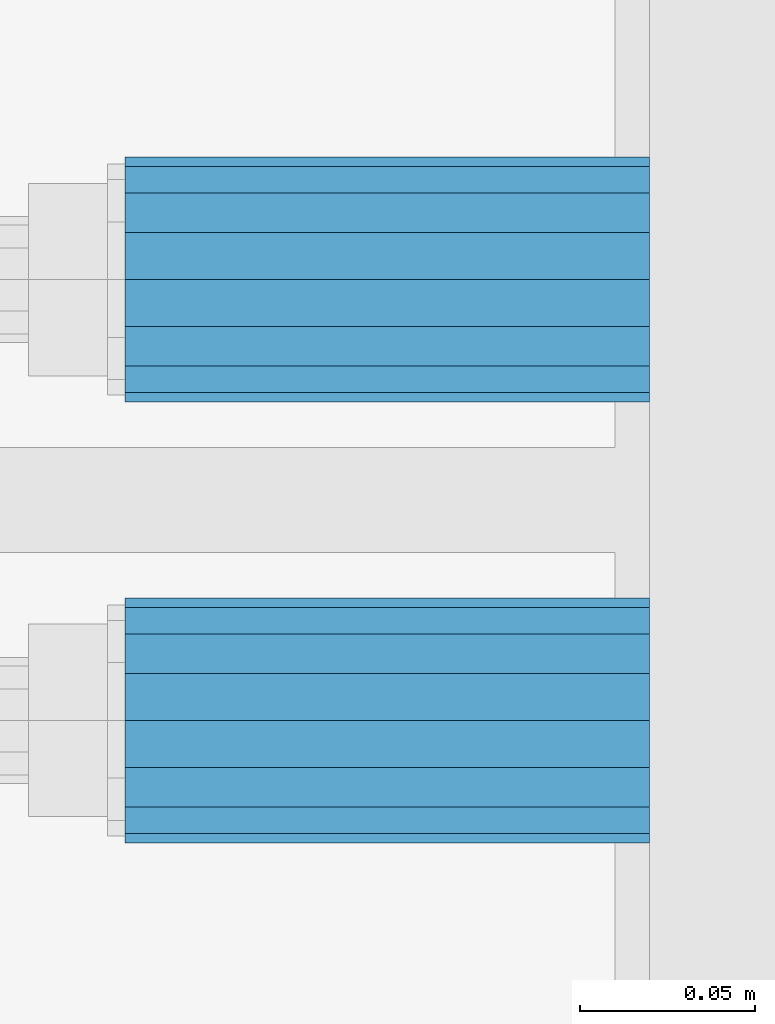
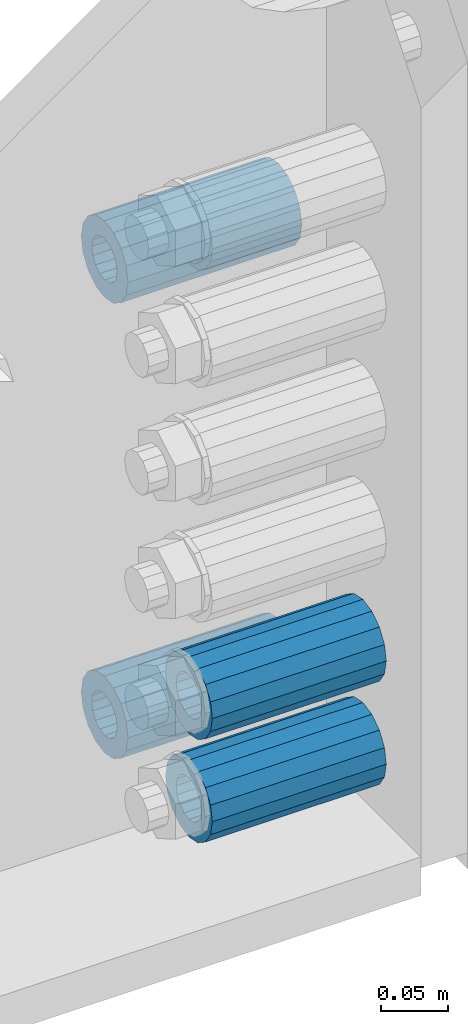
# One storey, part 177 of 270: 4 beams.
"""IFC2X3 building model written with IfcOpenShell, lengths in millimetres."""

from ifc_helpers import new_model, si_unit, frame, origin_with_axes, place, context, subcontext, project, spatial, faceted_brep, material, type_object, element, save


model = new_model("IFC2X3")

# Units and contexts
model_context = context("Model", 3, precision=1e-05, world=origin_with_axes())
body_context = subcontext(model_context, "Body", "Model", "MODEL_VIEW")
ifc_project = project(units=[si_unit("LENGTHUNIT", "METRE", prefix="MILLI"), si_unit("AREAUNIT", "SQUARE_METRE"), si_unit("VOLUMEUNIT", "CUBIC_METRE"), si_unit("MASSUNIT", "GRAM", prefix="KILO"), si_unit("TIMEUNIT", "SECOND"), si_unit("PLANEANGLEUNIT", "RADIAN"), si_unit("SOLIDANGLEUNIT", "STERADIAN"), si_unit("THERMODYNAMICTEMPERATUREUNIT", "DEGREE_CELSIUS"), si_unit("LUMINOUSINTENSITYUNIT", "LUMEN")], contexts=[model_context])

# Site, building, storey
site_placement = place(None, origin_with_axes())
site = spatial("IfcSite", under=ifc_project, at=site_placement, CompositionType="ELEMENT")
building_placement = place(site_placement, origin_with_axes())
building = spatial("IfcBuilding", under=site, at=building_placement, Name="Standard", CompositionType="ELEMENT")
storey_placement = place(building_placement, origin_with_axes())
storey = spatial("IfcBuildingStorey", under=building, at=storey_placement, Name="Undefined", CompositionType="ELEMENT", Elevation=0.0)

# Beams
ifc_material = material()
beam_type = type_object("IfcBeamType", PredefinedType="NOTDEFINED")
beam_1_placement = place(storey_placement, frame((20240.0, -17937.0, -397.0), z_axis=(0.0, 0.0, 1.0), x_axis=(1.0, 0.0, 0.0)))
element("IfcBeam", 1, at=beam_1_placement, inside=storey, type_object=beam_type, material=ifc_material, context=body_context, shape_type="Brep", body=[
    faceted_brep([(1.3317730918061e-07, -19.0000000004501, -6.27005647402257e-09), (0.0, -17.5537111177146, 7.27098521493673), (150.0, -17.5537111177146, 7.27098521493673), (150.0, -19.0, 0.0), (0.0, -13.4350288425449, 13.4350288425444), (150.0, -13.4350288425449, 13.4350288425444), (0.0, -7.27098521493826, 17.5537111177144), (150.0, -7.27098521493826, 17.5537111177144), (-6.33008312433958e-09, -4.50143033958739e-10, 18.9999999937299), (150.0, 0.0, 19.0), (0.0, 7.27098521493826, 17.5537111177144), (150.0, 7.27098521493826, 17.5537111177144), (0.0, 13.4350288425449, 13.4350288425444), (150.0, 13.4350288425449, 13.4350288425444), (0.0, 17.5537111177146, 7.27098521493673), (150.0, 17.5537111177146, 7.27098521493673), (-1.31170963868499e-07, 18.9999999995497, -6.27005647402257e-09), (150.0, 19.0, 0.0), (0.0, 17.5537111177146, -7.27098521493673), (150.0, 17.5537111177146, -7.27098521493673), (0.0, 13.4350288425449, -13.4350288425444), (150.0, 13.4350288425449, -13.4350288425444), (0.0, 7.27098521493826, -17.5537111177144), (150.0, 7.27098521493826, -17.5537111177144), (8.33460944704711e-09, -4.5025672079646e-10, -19.0000000062701), (150.0, 0.0, -19.0), (0.0, -7.27098521493826, -17.5537111177144), (150.0, -7.27098521493826, -17.5537111177144), (0.0, -13.4350288425449, -13.4350288425444), (150.0, -13.4350288425449, -13.4350288425444), (0.0, -17.5537111177146, -7.27098521493673), (150.0, -17.5537111177146, -7.27098521493673), (0.0, -35.0, -1.81898940354586e-12), (0.0, -32.335783637895, -13.3939201327794), (150.0, -32.3357836378964, -13.3939201327782), (150.0, -35.0, 0.0), (-1.81898940354586e-12, -24.7487373415292, -24.7487373415315), (150.0, -24.7487373415279, -24.7487373415292), (0.0, -13.3939201327782, -32.3357836378964), (150.0, -13.3939201327776, -32.335783637895), (0.0, 0.0, -35.0000000000018), (150.0, 0.0, -35.0), (0.0, 13.3939201327782, -32.3357836378964), (150.0, 13.3939201327776, -32.335783637895), (-1.81898940354586e-12, 24.7487373415292, -24.7487373415315), (150.0, 24.7487373415279, -24.7487373415291), (0.0, 32.335783637895, -13.3939201327794), (150.0, 32.3357836378964, -13.3939201327781), (0.0, 35.0, -1.81898940354586e-12), (150.0, 35.0, 0.0), (0.0, 32.335783637895, 13.3939201327776), (150.0, 32.3357836378964, 13.3939201327781), (1.81898940354586e-12, 24.7487373415292, 24.7487373415279), (150.0, 24.7487373415279, 24.7487373415292), (0.0, 13.3939201327781, 32.3357836378946), (150.0, 13.3939201327776, 32.335783637895), (0.0, 0.0, 34.9999999999982), (150.0, 0.0, 35.0), (0.0, -13.3939201327781, 32.3357836378946), (150.0, -13.3939201327776, 32.335783637895), (1.81898940354586e-12, -24.7487373415292, 24.7487373415279), (150.0, -24.7487373415279, 24.7487373415292), (0.0, -32.335783637895, 13.3939201327776), (150.0, -32.3357836378964, 13.3939201327781)], [[[0, 1, 2, 3]], [[1, 4, 5, 2]], [[4, 6, 7, 5]], [[6, 8, 9, 7]], [[8, 10, 11, 9]], [[10, 12, 13, 11]], [[12, 14, 15, 13]], [[14, 16, 17, 15]], [[16, 18, 19, 17]], [[18, 20, 21, 19]], [[20, 22, 23, 21]], [[22, 24, 25, 23]], [[24, 26, 27, 25]], [[26, 28, 29, 27]], [[28, 30, 31, 29]], [[30, 0, 3, 31]], [[32, 33, 34, 35]], [[33, 36, 37, 34]], [[36, 38, 39, 37]], [[38, 40, 41, 39]], [[40, 42, 43, 41]], [[42, 44, 45, 43]], [[44, 46, 47, 45]], [[46, 48, 49, 47]], [[48, 50, 51, 49]], [[50, 52, 53, 51]], [[52, 54, 55, 53]], [[54, 56, 57, 55]], [[56, 58, 59, 57]], [[58, 60, 61, 59]], [[60, 62, 63, 61]], [[62, 32, 35, 63]], [[37, 39, 41, 43, 45, 47, 49, 51, 53, 55, 57, 59, 61, 63, 35, 34], [5, 7, 9, 11, 13, 15, 17, 19, 21, 23, 25, 27, 29, 31, 3, 2]], [[62, 60, 58, 56, 54, 52, 50, 48, 46, 44, 42, 40, 38, 36, 33, 32], [30, 28, 26, 24, 22, 20, 18, 16, 14, 12, 10, 8, 6, 4, 1, 0]]]),
])
beam_2_placement = place(storey_placement, frame((20240.0, -18063.0, -718.0), z_axis=(0.0, 0.0, 1.0), x_axis=(1.0, 0.0, 0.0)))
element("IfcBeam", 2, at=beam_2_placement, inside=storey, type_object=beam_type, material=ifc_material, context=body_context, shape_type="Brep", body=[
    faceted_brep([(1.3317730918061e-07, -19.0000000004501, -6.27005647402257e-09), (0.0, -17.5537111177146, 7.27098521493673), (150.0, -17.5537111177146, 7.27098521493673), (150.0, -19.0, 0.0), (0.0, -13.4350288425449, 13.4350288425444), (150.0, -13.4350288425449, 13.4350288425444), (0.0, -7.27098521493826, 17.5537111177144), (150.0, -7.27098521493826, 17.5537111177144), (-6.33008312433958e-09, -4.50143033958739e-10, 18.9999999937299), (150.0, 0.0, 19.0), (0.0, 7.27098521493826, 17.5537111177144), (150.0, 7.27098521493826, 17.5537111177144), (0.0, 13.4350288425449, 13.4350288425444), (150.0, 13.4350288425449, 13.4350288425444), (0.0, 17.5537111177146, 7.27098521493673), (150.0, 17.5537111177146, 7.27098521493673), (-1.31170963868499e-07, 18.9999999995497, -6.27005647402257e-09), (150.0, 19.0, 0.0), (0.0, 17.5537111177146, -7.27098521493673), (150.0, 17.5537111177146, -7.27098521493673), (0.0, 13.4350288425449, -13.4350288425444), (150.0, 13.4350288425449, -13.4350288425444), (0.0, 7.27098521493826, -17.5537111177144), (150.0, 7.27098521493826, -17.5537111177144), (8.33460944704711e-09, -4.5025672079646e-10, -19.0000000062701), (150.0, 0.0, -19.0), (0.0, -7.27098521493826, -17.5537111177144), (150.0, -7.27098521493826, -17.5537111177144), (0.0, -13.4350288425449, -13.4350288425444), (150.0, -13.4350288425449, -13.4350288425444), (0.0, -17.5537111177146, -7.27098521493673), (150.0, -17.5537111177146, -7.27098521493673), (0.0, -35.0, -1.81898940354586e-12), (0.0, -32.335783637895, -13.3939201327794), (150.0, -32.3357836378964, -13.3939201327782), (150.0, -35.0, 0.0), (-1.81898940354586e-12, -24.7487373415292, -24.7487373415315), (150.0, -24.7487373415279, -24.7487373415292), (0.0, -13.3939201327782, -32.3357836378964), (150.0, -13.3939201327776, -32.335783637895), (0.0, 0.0, -35.0000000000018), (150.0, 0.0, -35.0), (0.0, 13.3939201327782, -32.3357836378964), (150.0, 13.3939201327776, -32.335783637895), (-1.81898940354586e-12, 24.7487373415292, -24.7487373415315), (150.0, 24.7487373415279, -24.7487373415291), (0.0, 32.335783637895, -13.3939201327794), (150.0, 32.3357836378964, -13.3939201327781), (0.0, 35.0, -1.81898940354586e-12), (150.0, 35.0, 0.0), (0.0, 32.335783637895, 13.3939201327776), (150.0, 32.3357836378964, 13.3939201327781), (1.81898940354586e-12, 24.7487373415292, 24.7487373415279), (150.0, 24.7487373415279, 24.7487373415292), (0.0, 13.3939201327781, 32.3357836378946), (150.0, 13.3939201327776, 32.335783637895), (0.0, 0.0, 34.9999999999982), (150.0, 0.0, 35.0), (0.0, -13.3939201327781, 32.3357836378946), (150.0, -13.3939201327776, 32.335783637895), (1.81898940354586e-12, -24.7487373415292, 24.7487373415279), (150.0, -24.7487373415279, 24.7487373415292), (0.0, -32.335783637895, 13.3939201327776), (150.0, -32.3357836378964, 13.3939201327781)], [[[0, 1, 2, 3]], [[1, 4, 5, 2]], [[4, 6, 7, 5]], [[6, 8, 9, 7]], [[8, 10, 11, 9]], [[10, 12, 13, 11]], [[12, 14, 15, 13]], [[14, 16, 17, 15]], [[16, 18, 19, 17]], [[18, 20, 21, 19]], [[20, 22, 23, 21]], [[22, 24, 25, 23]], [[24, 26, 27, 25]], [[26, 28, 29, 27]], [[28, 30, 31, 29]], [[30, 0, 3, 31]], [[32, 33, 34, 35]], [[33, 36, 37, 34]], [[36, 38, 39, 37]], [[38, 40, 41, 39]], [[40, 42, 43, 41]], [[42, 44, 45, 43]], [[44, 46, 47, 45]], [[46, 48, 49, 47]], [[48, 50, 51, 49]], [[50, 52, 53, 51]], [[52, 54, 55, 53]], [[54, 56, 57, 55]], [[56, 58, 59, 57]], [[58, 60, 61, 59]], [[60, 62, 63, 61]], [[62, 32, 35, 63]], [[37, 39, 41, 43, 45, 47, 49, 51, 53, 55, 57, 59, 61, 63, 35, 34], [5, 7, 9, 11, 13, 15, 17, 19, 21, 23, 25, 27, 29, 31, 3, 2]], [[62, 60, 58, 56, 54, 52, 50, 48, 46, 44, 42, 40, 38, 36, 33, 32], [30, 28, 26, 24, 22, 20, 18, 16, 14, 12, 10, 8, 6, 4, 1, 0]]]),
])
beam_3_placement = place(storey_placement, frame((20240.0, -17937.0, -812.0), z_axis=(0.0, 0.0, 1.0), x_axis=(1.0, 0.0, 0.0)))
element("IfcBeam", 3, at=beam_3_placement, inside=storey, type_object=beam_type, material=ifc_material, context=body_context, shape_type="Brep", body=[
    faceted_brep([(1.3317730918061e-07, -19.0000000004501, -6.27005647402257e-09), (0.0, -17.5537111177146, 7.27098521493673), (150.0, -17.5537111177146, 7.27098521493673), (150.0, -19.0, 0.0), (0.0, -13.4350288425449, 13.4350288425444), (150.0, -13.4350288425449, 13.4350288425444), (0.0, -7.27098521493826, 17.5537111177144), (150.0, -7.27098521493826, 17.5537111177144), (-6.33008312433958e-09, -4.50143033958739e-10, 18.9999999937299), (150.0, 0.0, 19.0), (0.0, 7.27098521493826, 17.5537111177144), (150.0, 7.27098521493826, 17.5537111177144), (0.0, 13.4350288425449, 13.4350288425444), (150.0, 13.4350288425449, 13.4350288425444), (0.0, 17.5537111177146, 7.27098521493673), (150.0, 17.5537111177146, 7.27098521493673), (-1.31170963868499e-07, 18.9999999995497, -6.27005647402257e-09), (150.0, 19.0, 0.0), (0.0, 17.5537111177146, -7.27098521493673), (150.0, 17.5537111177146, -7.27098521493673), (0.0, 13.4350288425449, -13.4350288425444), (150.0, 13.4350288425449, -13.4350288425444), (0.0, 7.27098521493826, -17.5537111177144), (150.0, 7.27098521493826, -17.5537111177144), (8.33460944704711e-09, -4.5025672079646e-10, -19.0000000062701), (150.0, 0.0, -19.0), (0.0, -7.27098521493826, -17.5537111177144), (150.0, -7.27098521493826, -17.5537111177144), (0.0, -13.4350288425449, -13.4350288425444), (150.0, -13.4350288425449, -13.4350288425444), (0.0, -17.5537111177146, -7.27098521493673), (150.0, -17.5537111177146, -7.27098521493673), (0.0, -35.0, -1.81898940354586e-12), (0.0, -32.335783637895, -13.3939201327794), (150.0, -32.3357836378964, -13.3939201327782), (150.0, -35.0, 0.0), (-1.81898940354586e-12, -24.7487373415292, -24.7487373415315), (150.0, -24.7487373415279, -24.7487373415292), (0.0, -13.3939201327782, -32.3357836378964), (150.0, -13.3939201327776, -32.335783637895), (0.0, 0.0, -35.0000000000018), (150.0, 0.0, -35.0), (0.0, 13.3939201327782, -32.3357836378964), (150.0, 13.3939201327776, -32.335783637895), (-1.81898940354586e-12, 24.7487373415292, -24.7487373415315), (150.0, 24.7487373415279, -24.7487373415291), (0.0, 32.335783637895, -13.3939201327794), (150.0, 32.3357836378964, -13.3939201327781), (0.0, 35.0, -1.81898940354586e-12), (150.0, 35.0, 0.0), (0.0, 32.335783637895, 13.3939201327776), (150.0, 32.3357836378964, 13.3939201327781), (1.81898940354586e-12, 24.7487373415292, 24.7487373415279), (150.0, 24.7487373415279, 24.7487373415292), (0.0, 13.3939201327781, 32.3357836378946), (150.0, 13.3939201327776, 32.335783637895), (0.0, 0.0, 34.9999999999982), (150.0, 0.0, 35.0), (0.0, -13.3939201327781, 32.3357836378946), (150.0, -13.3939201327776, 32.335783637895), (1.81898940354586e-12, -24.7487373415292, 24.7487373415279), (150.0, -24.7487373415279, 24.7487373415292), (0.0, -32.335783637895, 13.3939201327776), (150.0, -32.3357836378964, 13.3939201327781)], [[[0, 1, 2, 3]], [[1, 4, 5, 2]], [[4, 6, 7, 5]], [[6, 8, 9, 7]], [[8, 10, 11, 9]], [[10, 12, 13, 11]], [[12, 14, 15, 13]], [[14, 16, 17, 15]], [[16, 18, 19, 17]], [[18, 20, 21, 19]], [[20, 22, 23, 21]], [[22, 24, 25, 23]], [[24, 26, 27, 25]], [[26, 28, 29, 27]], [[28, 30, 31, 29]], [[30, 0, 3, 31]], [[32, 33, 34, 35]], [[33, 36, 37, 34]], [[36, 38, 39, 37]], [[38, 40, 41, 39]], [[40, 42, 43, 41]], [[42, 44, 45, 43]], [[44, 46, 47, 45]], [[46, 48, 49, 47]], [[48, 50, 51, 49]], [[50, 52, 53, 51]], [[52, 54, 55, 53]], [[54, 56, 57, 55]], [[56, 58, 59, 57]], [[58, 60, 61, 59]], [[60, 62, 63, 61]], [[62, 32, 35, 63]], [[37, 39, 41, 43, 45, 47, 49, 51, 53, 55, 57, 59, 61, 63, 35, 34], [5, 7, 9, 11, 13, 15, 17, 19, 21, 23, 25, 27, 29, 31, 3, 2]], [[62, 60, 58, 56, 54, 52, 50, 48, 46, 44, 42, 40, 38, 36, 33, 32], [30, 28, 26, 24, 22, 20, 18, 16, 14, 12, 10, 8, 6, 4, 1, 0]]]),
])
beam_4_placement = place(storey_placement, frame((20240.0, -18063.0, -812.0), z_axis=(0.0, 0.0, 1.0), x_axis=(1.0, 0.0, 0.0)))
element("IfcBeam", 4, at=beam_4_placement, inside=storey, type_object=beam_type, material=ifc_material, context=body_context, shape_type="Brep", body=[
    faceted_brep([(1.3317730918061e-07, -19.0000000004501, -6.27005647402257e-09), (0.0, -17.5537111177146, 7.27098521493673), (150.0, -17.5537111177146, 7.27098521493673), (150.0, -19.0, 0.0), (0.0, -13.4350288425449, 13.4350288425444), (150.0, -13.4350288425449, 13.4350288425444), (0.0, -7.27098521493826, 17.5537111177144), (150.0, -7.27098521493826, 17.5537111177144), (-6.33008312433958e-09, -4.50143033958739e-10, 18.9999999937299), (150.0, 0.0, 19.0), (0.0, 7.27098521493826, 17.5537111177144), (150.0, 7.27098521493826, 17.5537111177144), (0.0, 13.4350288425449, 13.4350288425444), (150.0, 13.4350288425449, 13.4350288425444), (0.0, 17.5537111177146, 7.27098521493673), (150.0, 17.5537111177146, 7.27098521493673), (-1.31170963868499e-07, 18.9999999995497, -6.27005647402257e-09), (150.0, 19.0, 0.0), (0.0, 17.5537111177146, -7.27098521493673), (150.0, 17.5537111177146, -7.27098521493673), (0.0, 13.4350288425449, -13.4350288425444), (150.0, 13.4350288425449, -13.4350288425444), (0.0, 7.27098521493826, -17.5537111177144), (150.0, 7.27098521493826, -17.5537111177144), (8.33460944704711e-09, -4.5025672079646e-10, -19.0000000062701), (150.0, 0.0, -19.0), (0.0, -7.27098521493826, -17.5537111177144), (150.0, -7.27098521493826, -17.5537111177144), (0.0, -13.4350288425449, -13.4350288425444), (150.0, -13.4350288425449, -13.4350288425444), (0.0, -17.5537111177146, -7.27098521493673), (150.0, -17.5537111177146, -7.27098521493673), (0.0, -35.0, -1.81898940354586e-12), (0.0, -32.335783637895, -13.3939201327794), (150.0, -32.3357836378964, -13.3939201327782), (150.0, -35.0, 0.0), (-1.81898940354586e-12, -24.7487373415292, -24.7487373415315), (150.0, -24.7487373415279, -24.7487373415292), (0.0, -13.3939201327782, -32.3357836378964), (150.0, -13.3939201327776, -32.335783637895), (0.0, 0.0, -35.0000000000018), (150.0, 0.0, -35.0), (0.0, 13.3939201327782, -32.3357836378964), (150.0, 13.3939201327776, -32.335783637895), (-1.81898940354586e-12, 24.7487373415292, -24.7487373415315), (150.0, 24.7487373415279, -24.7487373415291), (0.0, 32.335783637895, -13.3939201327794), (150.0, 32.3357836378964, -13.3939201327781), (0.0, 35.0, -1.81898940354586e-12), (150.0, 35.0, 0.0), (0.0, 32.335783637895, 13.3939201327776), (150.0, 32.3357836378964, 13.3939201327781), (1.81898940354586e-12, 24.7487373415292, 24.7487373415279), (150.0, 24.7487373415279, 24.7487373415292), (0.0, 13.3939201327781, 32.3357836378946), (150.0, 13.3939201327776, 32.335783637895), (0.0, 0.0, 34.9999999999982), (150.0, 0.0, 35.0), (0.0, -13.3939201327781, 32.3357836378946), (150.0, -13.3939201327776, 32.335783637895), (1.81898940354586e-12, -24.7487373415292, 24.7487373415279), (150.0, -24.7487373415279, 24.7487373415292), (0.0, -32.335783637895, 13.3939201327776), (150.0, -32.3357836378964, 13.3939201327781)], [[[0, 1, 2, 3]], [[1, 4, 5, 2]], [[4, 6, 7, 5]], [[6, 8, 9, 7]], [[8, 10, 11, 9]], [[10, 12, 13, 11]], [[12, 14, 15, 13]], [[14, 16, 17, 15]], [[16, 18, 19, 17]], [[18, 20, 21, 19]], [[20, 22, 23, 21]], [[22, 24, 25, 23]], [[24, 26, 27, 25]], [[26, 28, 29, 27]], [[28, 30, 31, 29]], [[30, 0, 3, 31]], [[32, 33, 34, 35]], [[33, 36, 37, 34]], [[36, 38, 39, 37]], [[38, 40, 41, 39]], [[40, 42, 43, 41]], [[42, 44, 45, 43]], [[44, 46, 47, 45]], [[46, 48, 49, 47]], [[48, 50, 51, 49]], [[50, 52, 53, 51]], [[52, 54, 55, 53]], [[54, 56, 57, 55]], [[56, 58, 59, 57]], [[58, 60, 61, 59]], [[60, 62, 63, 61]], [[62, 32, 35, 63]], [[37, 39, 41, 43, 45, 47, 49, 51, 53, 55, 57, 59, 61, 63, 35, 34], [5, 7, 9, 11, 13, 15, 17, 19, 21, 23, 25, 27, 29, 31, 3, 2]], [[62, 60, 58, 56, 54, 52, 50, 48, 46, 44, 42, 40, 38, 36, 33, 32], [30, 28, 26, 24, 22, 20, 18, 16, 14, 12, 10, 8, 6, 4, 1, 0]]]),
])

save(model, "model.ifc")
